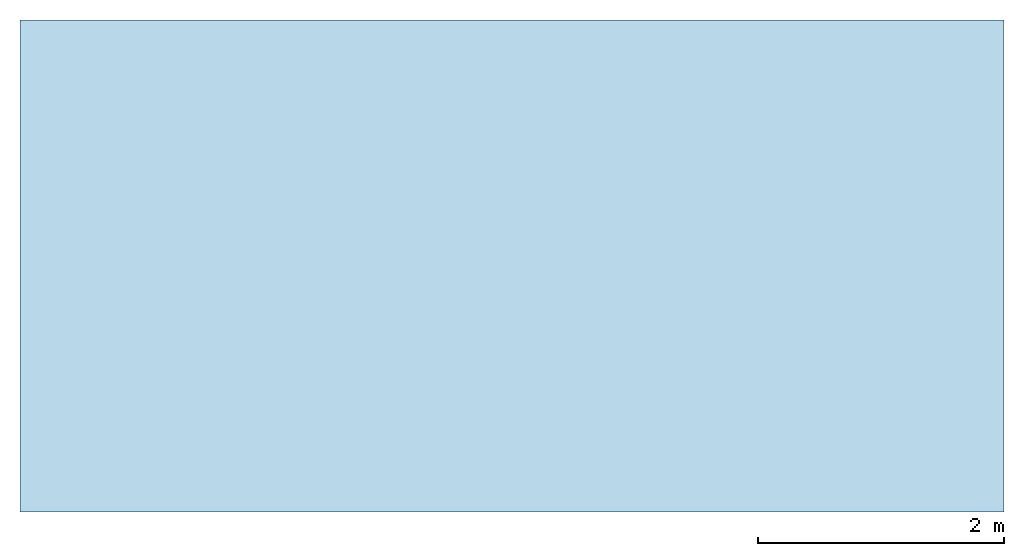
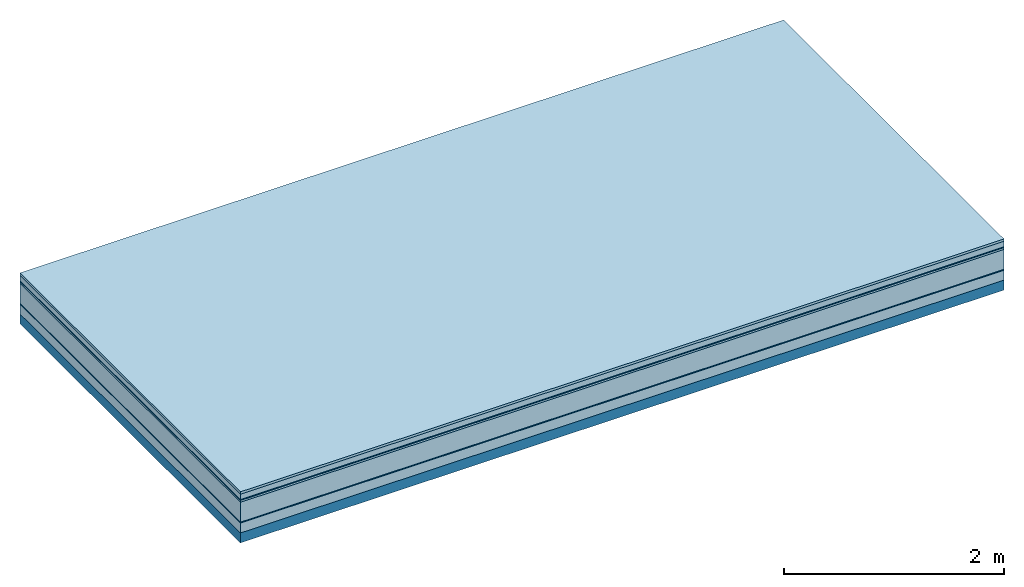
# One storey: 7 plates, 1 member, 1 element without a shape of its own.
"""IFC4 building model written with IfcOpenShell, lengths in metres."""

from ifc_helpers import new_model, si_unit, derived_unit, direction, frame, frame_2d, origin, origin_with_axes, place, context, project, spatial, rectangle, extrude, material, layer, layer_set, type_object, element, aggregate, save


model = new_model("IFC4")

# Units and contexts
plan_context = context("Plan", 3, precision=1e-05, world=origin(), true_north=direction((0.0, 1.0)))
model_context = context("Model", 3, precision=1e-05, world=origin(), true_north=direction((0.0, 1.0)))
ifc_project = project(units=[si_unit("LENGTHUNIT", "METRE"), derived_unit("SOUNDPRESSUREUNIT", [(si_unit("PRESSUREUNIT", "PASCAL", prefix="MICRO"), 0)]), si_unit("ENERGYUNIT", "JOULE", prefix="MEGA"), si_unit("MASSUNIT", "GRAM", prefix="KILO"), derived_unit("THERMALTRANSMITTANCEUNIT", [(si_unit("POWERUNIT", "WATT"), 1), (si_unit("AREAUNIT", "SQUARE_METRE"), -1), (si_unit("THERMODYNAMICTEMPERATUREUNIT", "KELVIN"), -1)]), derived_unit("AREADENSITYUNIT", [(si_unit("MASSUNIT", "GRAM", prefix="KILO"), 1), (si_unit("AREAUNIT", "SQUARE_METRE"), -1)]), derived_unit("USERDEFINED", [(si_unit("ENERGYUNIT", "JOULE", prefix="MEGA"), 1), (si_unit("AREAUNIT", "SQUARE_METRE"), -1)])], contexts=[plan_context, model_context])

# Site, building, storey
site = spatial("IfcSite", under=ifc_project)
building_placement = place(None, origin())
building = spatial("IfcBuilding", under=site, at=building_placement)
storey_placement = place(building_placement, origin())
storey = spatial("IfcBuildingStorey", under=building, at=storey_placement)

# Slab, member, plates
ifc_material_1 = material(Category="07.009")
ifc_layer_1 = layer(ifc_material_1, 0.026, Name="Use and protection layer 3")
ifc_material_2 = material(Category="07.011")
ifc_layer_2 = layer(ifc_material_2, 0.06, Name="Use and protection layer 2")
ifc_material_3 = material(Name="Protective layer + Fire protection cover RF1", Category="09.007")
ifc_layer_3 = layer(ifc_material_3, 0.01, Name="Use and protection layer 1")
ifc_material_4 = material(Name="Bituminous", Category="09.003")
ifc_layer_4 = layer(ifc_material_4, 0.02, Name="Seal")
ifc_material_5 = material(Name="Mineral wool", Category="10.008")
ifc_layer_5 = layer(ifc_material_5, 0.22, Name="Exterior insulation layer 1")
ifc_material_6 = material(Name="Vapor-permeable barrier", Category="09.006")
ifc_layer_6 = layer(ifc_material_6, 0.01, Name="layer / temporary roof")
ifc_material_7 = material(Category="01.002")
ifc_layer_7 = layer(ifc_material_7, 0.11, Name="above 1st layer")
ifc_material_8 = material(Name="Rigid, of the art")
ifc_layer_8 = layer(ifc_material_8, 0.0, Name="Bond")
ifc_layer_9 = layer(None, 0.11, Name="Support")
ifc_layer_set = layer_set([ifc_layer_1, ifc_layer_2, ifc_layer_3, ifc_layer_4, ifc_layer_5, ifc_layer_6, ifc_layer_7, ifc_layer_8, ifc_layer_9])
slab_type = type_object("IfcSlabType", Name="F0079", PredefinedType="NOTDEFINED", material=ifc_layer_set)
slab_placement = place(None, frame((0.0, 0.0, 0.0), z_axis=(0.0, 0.0, -1.0), x_axis=(1.0, 0.0, 0.0)))
slab = element("IfcSlab", 1, at=slab_placement, inside=storey, type_object=slab_type, material=ifc_layer_set, Name="Slab #1")
ifc_material_9 = material(Name="Solid timber panel")
member_placement = place(slab_placement, origin())
member = element("IfcMember", 2, at=member_placement, material=ifc_material_9, Name="Support", context=plan_context, shape_type="SweptSolid", body=[
    extrude(rectangle(XDim=1.0, YDim=0.11, at=frame_2d((0.5, 0.055), x_axis=(1.0, 0.0))), frame((0.0, 4.0, 0.456), z_axis=(0.0, -1.0, 0.0), x_axis=(1.0, 0.0, 0.0)), (0.0, 0.0, 1.0), 4.0),
    extrude(rectangle(XDim=1.0, YDim=0.11, at=frame_2d((0.5, 0.055), x_axis=(1.0, 0.0))), frame((1.0, 4.0, 0.456), z_axis=(0.0, -1.0, 0.0), x_axis=(1.0, 0.0, 0.0)), (0.0, 0.0, 1.0), 4.0),
    extrude(rectangle(XDim=1.0, YDim=0.11, at=frame_2d((0.5, 0.055), x_axis=(1.0, 0.0))), frame((2.0, 4.0, 0.456), z_axis=(0.0, -1.0, 0.0), x_axis=(1.0, 0.0, 0.0)), (0.0, 0.0, 1.0), 4.0),
    extrude(rectangle(XDim=1.0, YDim=0.11, at=frame_2d((0.5, 0.055), x_axis=(1.0, 0.0))), frame((3.0, 4.0, 0.456), z_axis=(0.0, -1.0, 0.0), x_axis=(1.0, 0.0, 0.0)), (0.0, 0.0, 1.0), 4.0),
    extrude(rectangle(XDim=1.0, YDim=0.11, at=frame_2d((0.5, 0.055), x_axis=(1.0, 0.0))), frame((4.0, 4.0, 0.456), z_axis=(0.0, -1.0, 0.0), x_axis=(1.0, 0.0, 0.0)), (0.0, 0.0, 1.0), 4.0),
    extrude(rectangle(XDim=1.0, YDim=0.11, at=frame_2d((0.5, 0.055), x_axis=(1.0, 0.0))), frame((5.0, 4.0, 0.456), z_axis=(0.0, -1.0, 0.0), x_axis=(1.0, 0.0, 0.0)), (0.0, 0.0, 1.0), 4.0),
    extrude(rectangle(XDim=1.0, YDim=0.11, at=frame_2d((0.5, 0.055), x_axis=(1.0, 0.0))), frame((6.0, 4.0, 0.456), z_axis=(0.0, -1.0, 0.0), x_axis=(1.0, 0.0, 0.0)), (0.0, 0.0, 1.0), 4.0),
    extrude(rectangle(XDim=1.0, YDim=0.11, at=frame_2d((0.5, 0.055), x_axis=(1.0, 0.0))), frame((7.0, 4.0, 0.456), z_axis=(0.0, -1.0, 0.0), x_axis=(1.0, 0.0, 0.0)), (0.0, 0.0, 1.0), 4.0),
])
plate_1_placement = place(slab_placement, origin())
plate_1 = element("IfcPlate", 3, at=plate_1_placement, material=ifc_material_1, Name="Use and protection layer 3", context=plan_context, shape_type="SweptSolid", body=[
    extrude(rectangle(XDim=8.0, YDim=4.0, at=frame_2d((4.0, 2.0), x_axis=(1.0, 0.0))), origin_with_axes(), (0.0, 0.0, 1.0), 0.026),
])
plate_2_placement = place(slab_placement, origin())
plate_2 = element("IfcPlate", 4, at=plate_2_placement, material=ifc_material_2, Name="Use and protection layer 2", context=plan_context, shape_type="SweptSolid", body=[
    extrude(rectangle(XDim=8.0, YDim=4.0, at=frame_2d((4.0, 2.0), x_axis=(1.0, 0.0))), frame((0.0, 0.0, 0.026), z_axis=(0.0, 0.0, 1.0), x_axis=(1.0, 0.0, 0.0)), (0.0, 0.0, 1.0), 0.06),
])
plate_3_placement = place(slab_placement, origin())
plate_3 = element("IfcPlate", 5, at=plate_3_placement, material=ifc_material_3, Name="Use and protection layer 1", context=plan_context, shape_type="SweptSolid", body=[
    extrude(rectangle(XDim=8.0, YDim=4.0, at=frame_2d((4.0, 2.0), x_axis=(1.0, 0.0))), frame((0.0, 0.0, 0.086), z_axis=(0.0, 0.0, 1.0), x_axis=(1.0, 0.0, 0.0)), (0.0, 0.0, 1.0), 0.01),
])
plate_4_placement = place(slab_placement, origin())
plate_4 = element("IfcPlate", 6, at=plate_4_placement, material=ifc_material_4, Name="Seal", context=plan_context, shape_type="SweptSolid", body=[
    extrude(rectangle(XDim=8.0, YDim=4.0, at=frame_2d((4.0, 2.0), x_axis=(1.0, 0.0))), frame((0.0, 0.0, 0.096), z_axis=(0.0, 0.0, 1.0), x_axis=(1.0, 0.0, 0.0)), (0.0, 0.0, 1.0), 0.02),
])
plate_5_placement = place(slab_placement, origin())
plate_5 = element("IfcPlate", 7, at=plate_5_placement, material=ifc_material_5, Name="Exterior insulation layer 1", context=plan_context, shape_type="SweptSolid", body=[
    extrude(rectangle(XDim=8.0, YDim=4.0, at=frame_2d((4.0, 2.0), x_axis=(1.0, 0.0))), frame((0.0, 0.0, 0.116), z_axis=(0.0, 0.0, 1.0), x_axis=(1.0, 0.0, 0.0)), (0.0, 0.0, 1.0), 0.22),
])
plate_6_placement = place(slab_placement, origin())
plate_6 = element("IfcPlate", 8, at=plate_6_placement, material=ifc_material_6, Name="layer / temporary roof", context=plan_context, shape_type="SweptSolid", body=[
    extrude(rectangle(XDim=8.0, YDim=4.0, at=frame_2d((4.0, 2.0), x_axis=(1.0, 0.0))), frame((0.0, 0.0, 0.336), z_axis=(0.0, 0.0, 1.0), x_axis=(1.0, 0.0, 0.0)), (0.0, 0.0, 1.0), 0.01),
])
plate_7_placement = place(slab_placement, origin())
plate_7 = element("IfcPlate", 9, at=plate_7_placement, material=ifc_material_7, Name="above 1st layer", context=plan_context, shape_type="SweptSolid", body=[
    extrude(rectangle(XDim=8.0, YDim=4.0, at=frame_2d((4.0, 2.0), x_axis=(1.0, 0.0))), frame((0.0, 0.0, 0.346), z_axis=(0.0, 0.0, 1.0), x_axis=(1.0, 0.0, 0.0)), (0.0, 0.0, 1.0), 0.11),
])
aggregate(slab, [plate_1, plate_2, plate_3, plate_4, plate_5, plate_6, plate_7, member])

save(model, "model.ifc")
